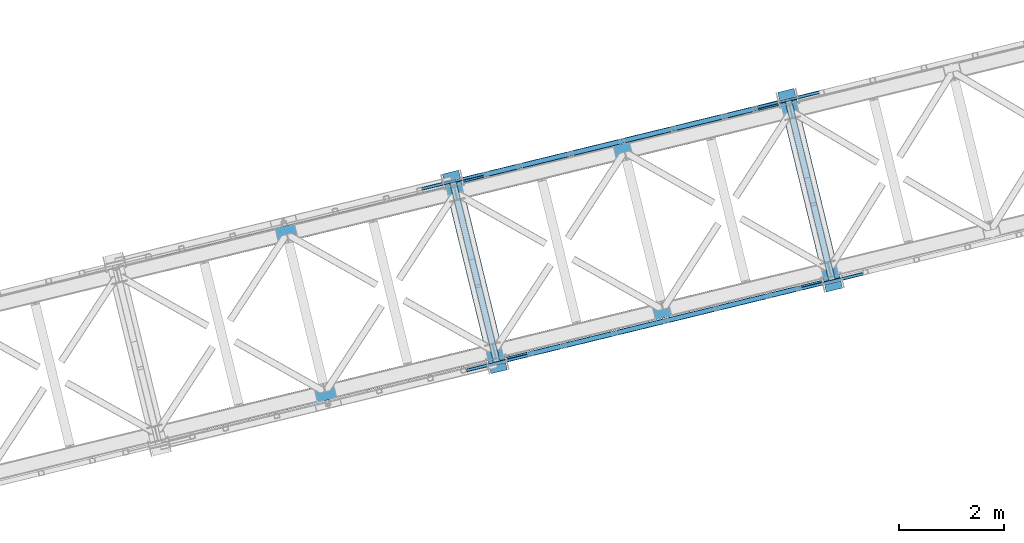
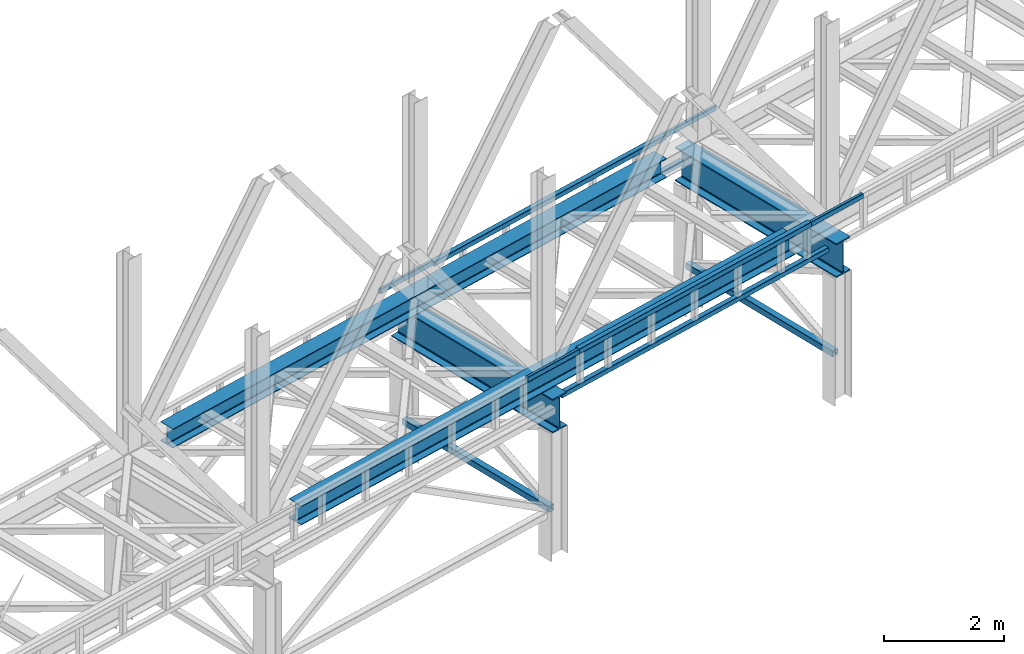
# One storey, part 17 of 92: 12 beams, 2 members.
"""IFC4 building model written with IfcOpenShell, lengths in millimetres."""

from ifc_helpers import new_model, entity, si_unit, converted_unit, derived_unit, direction, frame, origin, place, context, subcontext, project, spatial, indexed_curve, outline, extrude, material, type_object, element, save


model = new_model("IFC4")

# Units and contexts
model_context = context("Model", 3, precision=0.01, world=origin(), true_north=direction((6.12303176911189e-17, 1.0)))
plan_context = context("Plan", 3, precision=0.01, world=origin(), true_north=direction((6.12303176911189e-17, 1.0)))
body_context = subcontext(model_context, "Body", "Model", "MODEL_VIEW")
ifc_project = project(units=[si_unit("LENGTHUNIT", "METRE", prefix="MILLI"), si_unit("AREAUNIT", "SQUARE_METRE"), si_unit("VOLUMEUNIT", "CUBIC_METRE"), converted_unit("PLANEANGLEUNIT", "DEGREE", entity("IfcRatioMeasure", 0.0174532925199433), si_unit("PLANEANGLEUNIT", "RADIAN"), dimensions=[0, 0, 0, 0, 0, 0, 0]), si_unit("MASSUNIT", "GRAM", prefix="KILO"), derived_unit("MASSDENSITYUNIT", [(si_unit("MASSUNIT", "GRAM", prefix="KILO"), 1), (si_unit("LENGTHUNIT", "METRE"), -3)]), derived_unit("MOMENTOFINERTIAUNIT", [(si_unit("LENGTHUNIT", "METRE"), 4)]), si_unit("TIMEUNIT", "SECOND"), si_unit("FREQUENCYUNIT", "HERTZ"), si_unit("THERMODYNAMICTEMPERATUREUNIT", "DEGREE_CELSIUS"), derived_unit("THERMALTRANSMITTANCEUNIT", [(si_unit("MASSUNIT", "GRAM", prefix="KILO"), 1), (si_unit("THERMODYNAMICTEMPERATUREUNIT", "KELVIN"), -1), (si_unit("TIMEUNIT", "SECOND"), -3)]), derived_unit("VOLUMETRICFLOWRATEUNIT", [(si_unit("LENGTHUNIT", "METRE"), 3), (si_unit("TIMEUNIT", "SECOND"), -1)]), derived_unit("MASSFLOWRATEUNIT", [(si_unit("MASSUNIT", "GRAM", prefix="KILO"), 1), (si_unit("TIMEUNIT", "SECOND"), -1)]), derived_unit("ROTATIONALFREQUENCYUNIT", [(si_unit("TIMEUNIT", "SECOND"), -1)]), si_unit("ELECTRICCURRENTUNIT", "AMPERE"), si_unit("ELECTRICVOLTAGEUNIT", "VOLT"), si_unit("POWERUNIT", "WATT"), si_unit("FORCEUNIT", "NEWTON", prefix="KILO"), si_unit("ILLUMINANCEUNIT", "LUX"), si_unit("LUMINOUSFLUXUNIT", "LUMEN"), si_unit("LUMINOUSINTENSITYUNIT", "CANDELA"), derived_unit("USERDEFINED", [(si_unit("MASSUNIT", "GRAM", prefix="KILO"), -1), (si_unit("LENGTHUNIT", "METRE"), -2), (si_unit("TIMEUNIT", "SECOND"), 3), (si_unit("LUMINOUSFLUXUNIT", "LUMEN"), 1)]), derived_unit("LINEARVELOCITYUNIT", [(si_unit("LENGTHUNIT", "METRE"), 1), (si_unit("TIMEUNIT", "SECOND"), -1)]), si_unit("PRESSUREUNIT", "PASCAL"), derived_unit("USERDEFINED", [(si_unit("LENGTHUNIT", "METRE"), -2), (si_unit("MASSUNIT", "GRAM", prefix="KILO"), 1), (si_unit("TIMEUNIT", "SECOND"), -2)]), derived_unit("LINEARFORCEUNIT", [(si_unit("MASSUNIT", "GRAM", prefix="KILO"), 1), (si_unit("LENGTHUNIT", "METRE"), 1), (si_unit("TIMEUNIT", "SECOND"), -2), (si_unit("LENGTHUNIT", "METRE"), -1)]), derived_unit("PLANARFORCEUNIT", [(si_unit("MASSUNIT", "GRAM", prefix="KILO"), 1), (si_unit("LENGTHUNIT", "METRE"), 1), (si_unit("TIMEUNIT", "SECOND"), -2), (si_unit("LENGTHUNIT", "METRE"), -2)])], contexts=[model_context, plan_context])

# Site, building, storey
site_placement = place(None, origin())
site = spatial("IfcSite", under=ifc_project, at=site_placement, CompositionType="ELEMENT")
building_placement = place(site_placement, origin())
building = spatial("IfcBuilding", under=site, at=building_placement, CompositionType="ELEMENT")
storey_placement = place(building_placement, frame((0.0, 0.0, 15900.0)))
storey = spatial("IfcBuildingStorey", under=building, at=storey_placement, Name="05", CompositionType="ELEMENT", Elevation=15900.0)

# Beams
ifc_material = material(Name="Metal painted (White)")
beam_type = type_object("IfcBeamType", PredefinedType="BEAM")
placement = place(storey_placement, origin())
element("IfcBeam", 1, at=placement, inside=storey, type_object=beam_type, material=ifc_material, ObjectType="Steel Beam", PredefinedType="BEAM", context=body_context, shape_type="SweptSolid", body=[
    extrude(outline(indexed_curve([(-345.500000000002, -159.999999999997), (-322.5, -159.999999999997), (-322.5, -37.4999999999995), (-320.216385975338, -26.019497029052), (-313.713203435595, -16.2867965644011), (-303.980502970953, -9.78361402465815), (-292.499999999998, -7.49999999999633), (292.500000000001, -7.49999999999633), (303.980502970953, -9.78361402465815), (313.713203435597, -16.2867965644011), (320.21638597534, -26.019497029052), (322.5, -37.4999999999995), (322.5, -159.999999999997), (345.499999999997, -159.999999999997), (345.499999999997, 159.999999999997), (322.5, 159.999999999997), (322.5, 37.4999999999995), (320.21638597534, 26.019497029052), (313.713203435597, 16.2867965644011), (303.980502970953, 9.78361402465815), (292.500000000001, 7.50000000000079), (-292.499999999998, 7.50000000000526), (-303.98050297095, 9.78361402466262), (-313.713203435591, 16.2867965644011), (-320.216385975338, 26.0194970290475), (-322.5, 37.4999999999995), (-322.5, 160.000000000002), (-345.500000000002, 159.999999999997), (-345.500000000002, -159.999999999997)], self_intersect=False)), frame((-35697.8, 8488.15, 2947.5), z_axis=(-0.236826092990338, 0.971552058141473, 0.0), x_axis=(0.0, 0.0, 1.0)), (0.0, 0.0, 1.0), 3899.99999999999),
])
element("IfcBeam", 2, at=placement, inside=storey, type_object=beam_type, material=ifc_material, ObjectType="Steel Beam", PredefinedType="BEAM", context=body_context, shape_type="SweptSolid", body=[
    extrude(outline(indexed_curve([(-345.500000000002, -159.999999999992), (-322.5, -159.999999999992), (-322.5, -37.4999999999948), (-320.216385975338, -26.0194970290473), (-313.713203435595, -16.2867965643967), (-303.980502970953, -9.78361402465343), (-292.499999999998, -7.49999999999633), (292.500000000001, -7.49999999999633), (303.980502970953, -9.78361402465343), (313.713203435597, -16.2867965643967), (320.21638597534, -26.0194970290473), (322.5, -37.4999999999948), (322.5, -159.999999999992), (345.499999999997, -159.999999999992), (345.499999999997, 160.000000000006), (322.5, 160.000000000006), (322.5, 37.5000000000037), (320.21638597534, 26.0194970290562), (313.713203435597, 16.2867965644056), (303.980502970953, 9.78361402466287), (292.500000000001, 7.50000000000526), (-292.499999999998, 7.50000000000526), (-303.98050297095, 9.78361402466708), (-313.713203435591, 16.2867965644014), (-320.216385975338, 26.019497029052), (-322.5, 37.5000000000037), (-322.5, 160.000000000001), (-345.500000000002, 160.000000000006), (-345.500000000002, -159.999999999992)], self_intersect=False)), frame((-29334.14, 10039.36, 2947.5), z_axis=(-0.23682609299033, 0.971552058141475, 0.0), x_axis=(0.0, 0.0, 1.0)), (0.0, 0.0, 1.0), 3899.99999999999),
])
element("IfcBeam", 3, at=placement, inside=storey, type_object=beam_type, material=ifc_material, ObjectType="Steel Beam", PredefinedType="BEAM", context=body_context, shape_type="SweptSolid", body=[
    extrude(outline(indexed_curve([(-195.999999999999, -150.000000000003), (-179.999999999996, -150.000000000003), (-179.999999999996, -27.7500000000041), (-178.325349715245, -19.3309644879692), (-173.556349186101, -12.1936508138986), (-166.419035512029, -7.42465028475491), (-157.999999999997, -5.7500000000032), (158.000000000005, -5.7500000000032), (166.419035512033, -7.42465028475491), (173.556349186107, -12.1936508138986), (178.325349715251, -19.3309644879692), (180.0, -27.7500000000041), (180.0, -150.000000000003), (196.000000000005, -150.000000000003), (196.000000000005, 149.999999999998), (180.0, 149.999999999998), (180.0, 27.7499999999978), (178.325349715251, 19.330964487965), (173.556349186107, 12.1936508138923), (166.419035512033, 7.42465028474965), (158.000000000005, 5.74999999999584), (-157.999999999997, 5.74999999999584), (-166.419035512029, 7.42465028474965), (-173.556349186101, 12.1936508138933), (-178.325349715245, 19.330964487965), (-179.999999999996, 27.7499999999978), (-179.999999999996, 150.0), (-195.999999999999, 149.999999999998), (-195.999999999999, -150.000000000003)], self_intersect=False)), frame((-41354.67, 7520.94, 3489.0), z_axis=(0.971552058141476, 0.236826092990324, 0.0), x_axis=(0.0, 0.0, 1.0)), (0.0, 0.0, 1.0), 11400.0),
])
element("IfcBeam", 4, at=placement, inside=storey, type_object=beam_type, material=ifc_material, ObjectType="Steel Beam", PredefinedType="BEAM", context=body_context, shape_type="SweptSolid", body=[
    extrude(outline(indexed_curve([(-195.999999999999, -150.000000000002), (-179.999999999996, -150.000000000002), (-179.999999999996, -27.750000000002), (-178.325349715245, -19.3309644879681), (-173.556349186101, -12.1936508138975), (-166.419035512029, -7.42465028475491), (-157.999999999997, -5.75000000000215), (158.000000000005, -5.75000000000215), (166.419035512033, -7.42465028475491), (173.556349186107, -12.1936508138975), (178.325349715251, -19.3309644879681), (180.0, -27.750000000002), (180.0, -150.000000000002), (196.000000000005, -150.000000000002), (196.000000000005, 149.999999999998), (180.0, 149.999999999998), (180.0, 27.7499999999978), (178.325349715251, 19.330964487966), (173.556349186107, 12.1936508138933), (166.419035512033, 7.4246502847507), (158.000000000005, 5.74999999999794), (-157.999999999997, 5.74999999999794), (-166.419035512029, 7.4246502847486), (-173.556349186101, 12.1936508138912), (-178.325349715247, 19.330964487966), (-179.999999999996, 27.7499999999957), (-179.999999999996, 149.999999999998), (-195.999999999999, 149.999999999998), (-195.999999999999, -150.000000000002)], self_intersect=False)), frame((-42088.83, 10532.75, 3489.0), z_axis=(0.971552058141477, 0.236826092990322, 0.0), x_axis=(0.0, 0.0, 1.0)), (0.0, 0.0, 1.0), 11400.0),
])
element("IfcBeam", 5, at=placement, inside=storey, type_object=beam_type, material=ifc_material, ObjectType="Steel Beam", PredefinedType="BEAM", context=body_context, shape_type="SweptSolid", body=[
    extrude(outline(indexed_curve([(29.4768951152948, -56.8428769008151), (33.3787015556177, -56.8428769008151), (36.9835006656516, -55.3497202198128), (39.7424944584837, -52.5907264269822), (41.2356511394923, -48.9859273169492), (56.8428769008144, 29.4768951153021), (56.8428769008163, 33.3787015556236), (55.3497202198083, 36.983500665662), (52.5907264269817, 39.7424944584911), (48.9859273169474, 41.2356511394989), (-29.4768951153043, 56.8428769008214), (-33.3787015556268, 56.8428769008235), (-36.9835006656611, 55.3497202198191), (-39.7424944584921, 52.5907264269883), (-41.2356511395007, 48.9859273169553), (-56.8428769008228, -29.476895115296), (-56.8428769008247, -33.3787015556175), (-55.3497202198188, -36.9835006656555), (-52.5907264269907, -39.7424944584827), (-48.9859273169579, -41.2356511394924), (29.4768951152948, -56.8428769008151)], self_intersect=False), holes=[indexed_curve([(-50.9634988887243, -25.5484203233641), (-37.307176347567, 43.1065493048579), (-35.8140196665605, 46.7113484148914), (-33.0550258737274, 49.4703422077217), (-29.450226763691, 50.9634988887257), (-25.5484203233706, 50.963498888724), (43.106549304852, 37.3071763475664), (46.7113484148832, 35.8140196665592), (49.4703422077129, 33.0550258737295), (50.9634988887188, 29.4502267636915), (50.9634988887169, 25.54842032337), (37.3071763475586, -43.1065493048518), (35.81401966655, -46.7113484148849), (33.0550258737224, -49.4703422077141), (29.4502267636851, -50.9634988887179), (25.5484203233636, -50.963498888716), (-43.1065493048565, -37.3071763475567), (-46.7113484148907, -35.8140196665489), (-49.4703422077195, -33.0550258737194), (-50.9634988887242, -29.450226763686), (-50.9634988887243, -25.5484203233641)], self_intersect=False)]), frame((-36379.75, 12130.26, 3118.0), z_axis=(0.971552058141621, 0.236826092989728, 0.0), x_axis=(-0.232275546019818, 0.952883957770662, 0.195090322016531)), (0.0, 0.0, 1.0), 6149.99999999998),
])
element("IfcBeam", 6, at=placement, inside=storey, type_object=beam_type, material=ifc_material, ObjectType="Steel Beam", PredefinedType="BEAM", context=body_context, shape_type="SweptSolid", body=[
    extrude(outline(indexed_curve([(29.4768951153914, -56.8428769007589), (33.378701555713, -56.8428769007589), (36.9835006657449, -55.3497202197486), (39.742494458576, -52.590726426912), (41.2356511395787, -48.9859273168765), (56.8428769007726, 29.4768951154003), (56.8428769007651, 33.3787015557224), (55.3497202197521, 36.9835006657516), (52.5907264269217, 39.7424944585804), (48.985927316883, 41.2356511395828), (-29.4768951153921, 56.8428769007767), (-33.3787015557146, 56.8428769007724), (-36.9835006657473, 55.3497202197579), (-39.7424944585747, 52.5907264269294), (-41.2356511395774, 48.9859273168939), (-56.8428769007734, -29.4768951153824), (-56.8428769007669, -33.3787015557044), (-55.3497202197555, -36.9835006657421), (-52.5907264269213, -39.7424944585673), (-48.9859273168837, -41.235651139565), (29.4768951153914, -56.8428769007589)], self_intersect=False), holes=[indexed_curve([(-50.9634988886772, -25.5484203234418), (-37.307176347632, 43.1065493048025), (-35.8140196666283, 46.7113484148378), (-33.055025873804, 49.4703422076669), (-29.4502267637722, 50.9634988886772), (-25.5484203234488, 50.9634988886857), (43.106549304796, 37.3071763476402), (46.7113484148319, 35.8140196666341), (49.470342207663, 33.0550258738095), (50.9634988886741, 29.4502267637807), (50.9634988886805, 25.5484203234587), (37.3071763476354, -43.1065493047855), (35.8140196666347, -46.7113484148214), (33.0550258738057, -49.4703422076584), (29.4502267637739, -50.9634988886687), (25.5484203234514, -50.963498888673), (-43.1065493047935, -37.3071763476275), (-46.7113484148281, -35.814019666626), (-49.4703422076613, -33.055025873801), (-50.9634988886727, -29.4502267637633), (-50.9634988886772, -25.5484203234418)], self_intersect=False)]), frame((-35991.13, 12224.99, 3830.0), z_axis=(0.971552058141621, 0.236826092989728, 0.0), x_axis=(0.232275546019893, -0.952883957770972, -0.19509032201493)), (0.0, 0.0, 1.0), 5349.99999999999),
])
element("IfcBeam", 7, at=placement, inside=storey, type_object=beam_type, material=ifc_material, ObjectType="Steel Beam", PredefinedType="BEAM", context=body_context, shape_type="SweptSolid", body=[
    extrude(outline(indexed_curve([(9.86118950714821, -52.94107046051), (13.7629959474724, -52.94107046051), (17.3677950575093, -51.4479137795159), (20.1267888503473, -48.6889199866879), (21.6199455313576, -45.0841208766564), (37.2271712928086, 33.3787015555692), (37.2271712928189, 37.2805079958903), (35.7340146118184, 40.8853071059286), (32.9750208189941, 43.6443008987626), (29.3702217089642, 45.1374575797804), (-9.86118950715112, 52.9410704605061), (-13.7629959474724, 52.94107046051), (-17.3677950575122, 51.447913779512), (-20.1267888503473, 48.6889199866879), (-21.6199455313597, 45.0841208766568), (-37.2271712928107, -33.3787015555687), (-37.2271712928189, -37.2805079958903), (-35.7340146118213, -40.8853071059325), (-32.9750208189941, -43.6443008987626), (-29.370221708965, -45.1374575797846), (9.86118950714821, -52.94107046051)], self_intersect=False), holes=[indexed_curve([(-31.3477932807058, -29.4502267636464), (-17.6914707394355, 39.204742864553), (-16.1983140584179, 42.8095419745831), (-13.439320265588, 45.5685357674083), (-9.83452115555026, 47.0616924484066), (-5.9327147152257, 47.0616924483977), (23.4908436968584, 41.2089827878538), (27.0956428068893, 39.7158261068403), (29.8546365997166, 36.9568323140057), (31.3477932807141, 33.3520332039679), (31.3477932807058, 29.4502267636464), (17.6914707394355, -39.204742864553), (16.1983140584221, -42.8095419745839), (13.4393202655851, -45.5685357674121), (9.83452115554819, -47.0616924484062), (5.93271471522983, -47.0616924483985), (-23.4908436968584, -41.2089827878538), (-27.0956428068893, -39.7158261068403), (-29.8546365997094, -36.9568323140071), (-31.3477932807141, -33.3520332039679), (-31.3477932807058, -29.4502267636464)], self_intersect=False)]), frame((-37161.73, 11960.23, 3830.0), z_axis=(0.971552058141752, 0.236826092989194, 0.0), x_axis=(-0.232275546019742, 0.952883957770353, 0.195090322018133)), (0.0, 0.0, 1.0), 1199.99999999998),
])
element("IfcBeam", 8, at=placement, inside=storey, type_object=beam_type, material=ifc_material, ObjectType="Steel Beam", PredefinedType="BEAM", context=body_context, shape_type="SweptSolid", body=[
    extrude(outline(indexed_curve([(9.86118950714344, -52.9410704605112), (13.7629959474656, -52.9410704605112), (17.3677950575047, -51.4479137795179), (20.1267888503399, -48.6889199866896), (21.6199455313537, -45.0841208766589), (37.2271712928143, 33.3787015555648), (37.227171292823, 37.2805079958863), (35.7340146118239, 40.8853071059246), (32.9750208189968, 43.6443008987596), (29.3702217089691, 45.1374575797773), (-9.86118950714429, 52.9410704605069), (-13.7629959474676, 52.9410704605116), (-17.3677950575055, 51.4479137795136), (-20.1267888503399, 48.6889199866896), (-21.6199455313537, 45.0841208766589), (-37.2271712928143, -33.3787015555648), (-37.2271712928209, -37.2805079958867), (-35.7340146118227, -40.8853071059293), (-32.9750208189989, -43.6443008987591), (-29.3702217089699, -45.1374575797815), (9.86118950714344, -52.9410704605112)], self_intersect=False), holes=[indexed_curve([(-31.3477932807069, -29.4502267636435), (-17.6914707394291, 39.2047428645544), (-16.1983140584143, 42.8095419745849), (-13.439320265582, 45.5685357674094), (-9.83452115554203, 47.061692448407), (-5.9327147152216, 47.0616924483985), (23.4908436968629, 41.2089827878513), (27.0956428068946, 39.7158261068372), (29.8546365997175, 36.9568323140031), (31.3477932807197, 33.3520332039642), (31.3477932807111, 29.4502267636427), (17.6914707394333, -39.2047428645553), (16.1983140584184, -42.8095419745858), (13.4393202655811, -45.5685357674137), (9.83452115554409, -47.0616924484074), (5.93271471522366, -47.0616924483989), (-23.4908436968609, -41.2089827878517), (-27.0956428068895, -39.7158261068383), (-29.8546365997142, -36.9568323140082), (-31.3477932807156, -33.352033203965), (-31.3477932807069, -29.4502267636435)], self_intersect=False)]), frame((-30796.99, 13507.06, 3830.0), z_axis=(0.971552058141691, 0.236826092989445, 0.0), x_axis=(-0.232275546019865, 0.952883957770302, 0.195090322018236)), (0.0, 0.0, 1.0), 1200.00000000001),
])
element("IfcBeam", 9, at=placement, inside=storey, type_object=beam_type, material=ifc_material, ObjectType="Steel Beam", PredefinedType="BEAM", context=body_context, shape_type="SweptSolid", body=[
    extrude(outline(indexed_curve([(29.4768951153284, -56.8428769008039), (33.3787015556499, -56.8428769008039), (36.9835006656849, -55.3497202197958), (39.7424944585137, -52.5907264269679), (41.2356511395206, -48.9859273169341), (56.8428769008042, 29.4768951153248), (56.8428769008037, 33.3787015556486), (55.349720219797, 36.9835006656857), (52.5907264269665, 39.7424944585117), (48.9859273169325, 41.2356511395176), (-29.4768951153288, 56.8428769008018), (-33.3787015556503, 56.8428769008018), (-36.9835006656844, 55.3497202197979), (-39.7424944585142, 52.5907264269658), (-41.2356511395214, 48.9859273169299), (-56.8428769008051, -29.476895115329), (-56.8428769008041, -33.3787015556507), (-55.3497202197966, -36.9835006656836), (-52.5907264269669, -39.7424944585138), (-48.985927316933, -41.2356511395197), (29.4768951153284, -56.8428769008039)], self_intersect=False), holes=[indexed_curve([(-50.9634988887085, -25.5484203233942), (-37.3071763475859, 43.1065493048346), (-35.8140196665801, 46.7113484148686), (-33.0550258737493, 49.4703422077006), (-29.4502267637143, 50.9634988887087), (-25.5484203233908, 50.9634988887083), (43.1065493048363, 37.3071763475849), (46.7113484148724, 35.8140196665786), (49.470342207701, 33.0550258737486), (50.9634988887077, 29.4502267637115), (50.9634988887076, 25.54842032339), (37.307176347583, -43.1065493048385), (35.8140196665761, -46.7113484148723), (33.0550258737489, -49.4703422077027), (29.4502267637147, -50.9634988887066), (25.5484203233923, -50.9634988887064), (-43.1065493048349, -37.307176347583), (-46.7113484148709, -35.8140196665767), (-49.4703422076989, -33.055025873749), (-50.9634988887075, -29.4502267637159), (-50.9634988887085, -25.5484203233942)], self_intersect=False)]), frame((-35548.72, 8721.08, 3118.0), z_axis=(0.971552058141591, 0.236826092989854, 0.0), x_axis=(-0.232275546019904, 0.95288395777074, 0.195090322016049)), (0.0, 0.0, 1.0), 6149.99999999998),
])
element("IfcBeam", 10, at=placement, inside=storey, type_object=beam_type, material=ifc_material, ObjectType="Steel Beam", PredefinedType="BEAM", context=body_context, shape_type="SweptSolid", body=[
    extrude(outline(indexed_curve([(29.4768951153914, -56.842876900761), (33.378701555712, -56.842876900761), (36.983500665745, -55.3497202197511), (39.7424944585721, -52.5907264269138), (41.235651139575, -48.9859273168784), (56.8428769007732, 29.4768951153975), (56.842876900768, 33.3787015557192), (55.3497202197561, 36.9835006657483), (52.5907264269239, 39.7424944585777), (48.9859273168883, 41.2356511395796), (-29.476895115389, 56.8428769007782), (-33.3787015557115, 56.8428769007741), (-36.9835006657453, 55.34972021976), (-39.7424944585708, 52.5907264269312), (-41.2356511395737, 48.9859273168958), (-56.8428769007719, -29.4768951153801), (-56.8428769007667, -33.3787015557018), (-55.3497202197565, -36.9835006657394), (-52.5907264269234, -39.7424944585645), (-48.9859273168859, -41.2356511395624), (29.4768951153914, -56.842876900761)], self_intersect=False), holes=[indexed_curve([(-50.9634988886785, -25.5484203234391), (-37.3071763476287, 43.1065493048042), (-35.8140196666226, 46.711348414839), (-33.0550258738003, 49.4703422076684), (-29.4502267637694, 50.9634988886787), (-25.548420323445, 50.9634988886868), (43.106549304797, 37.3071763476382), (46.7113484148338, 35.8140196666316), (49.4703422076658, 33.0550258738067), (50.9634988886777, 29.4502267637776), (50.9634988886819, 25.5484203234561), (37.3071763476341, -43.1065493047876), (35.8140196666342, -46.7113484148237), (33.055025873803, -49.4703422076601), (29.4502267637711, -50.9634988886702), (25.5484203234486, -50.9634988886743), (-43.1065493047934, -37.3071763476257), (-46.711348414829, -35.8140196666237), (-49.4703422076652, -33.055025873798), (-50.9634988886733, -29.4502267637608), (-50.9634988886785, -25.5484203234391)], self_intersect=False)]), frame((-35160.1, 8815.81, 3830.0), z_axis=(0.971552058141591, 0.236826092989854, 0.0), x_axis=(0.232275546019955, -0.952883957770947, -0.195090322014981)), (0.0, 0.0, 1.0), 5349.99999999999),
])
element("IfcBeam", 11, at=placement, inside=storey, type_object=beam_type, material=ifc_material, ObjectType="Steel Beam", PredefinedType="BEAM", context=body_context, shape_type="SweptSolid", body=[
    extrude(outline(indexed_curve([(9.86118950714636, -52.9410704605107), (13.7629959474695, -52.9410704605107), (17.3677950575075, -51.447913779517), (20.1267888503426, -48.6889199866885), (21.6199455313572, -45.0841208766579), (37.2271712928125, 33.3787015555668), (37.2271712928199, 37.2805079958885), (35.7340146118217, 40.8853071059265), (32.9750208189965, 43.6443008987609), (29.3702217089666, 45.1374575797788), (-9.8611895071472, 52.9410704605064), (-13.7629959474695, 52.9410704605107), (-17.3677950575084, 51.4479137795127), (-20.1267888503426, 48.6889199866885), (-21.6199455313572, 45.0841208766579), (-37.2271712928125, -33.3787015555668), (-37.2271712928199, -37.2805079958885), (-35.7340146118225, -40.8853071059308), (-32.9750208189965, -43.6443008987609), (-29.3702217089675, -45.1374575797831), (9.86118950714636, -52.9410704605107)], self_intersect=False), holes=[indexed_curve([(-31.3477932807053, -29.4502267636452), (-17.6914707394323, 39.2047428645537), (-16.1983140584177, 42.8095419745843), (-13.4393202655865, 45.5685357674091), (-9.83452115554665, 47.0616924484069), (-5.93271471522212, 47.0616924483978), (23.4908436968607, 41.2089827878526), (27.0956428068914, 39.7158261068389), (29.8546365997166, 36.9568323140045), (31.3477932807159, 33.3520332039663), (31.3477932807084, 29.4502267636446), (17.6914707394344, -39.2047428645542), (16.1983140584197, -42.8095419745847), (13.4393202655846, -45.5685357674132), (9.83452115554871, -47.0616924484073), (5.93271471522725, -47.0616924483988), (-23.4908436968597, -41.2089827878528), (-27.0956428068894, -39.7158261068393), (-29.8546365997112, -36.95683231401), (-31.3477932807138, -33.3520332039667), (-31.3477932807053, -29.4502267636452)], self_intersect=False)]), frame((-36321.23, 8512.19, 3830.0), z_axis=(0.971552058141721, 0.236826092989319, 0.0), x_axis=(-0.232275546019804, 0.952883957770327, 0.195090322018185)), (0.0, 0.0, 1.0), 1199.99999999998),
])
element("IfcBeam", 12, at=placement, inside=storey, type_object=beam_type, material=ifc_material, ObjectType="Steel Beam", PredefinedType="BEAM", context=body_context, shape_type="SweptSolid", body=[
    extrude(outline(indexed_curve([(9.86118950714821, -52.94107046051), (13.7629959474724, -52.94107046051), (17.3677950575093, -51.4479137795159), (20.1267888503473, -48.6889199866879), (21.6199455313597, -45.0841208766568), (37.2271712928107, 33.3787015555687), (37.2271712928189, 37.2805079958903), (35.7340146118184, 40.8853071059286), (32.9750208189941, 43.6443008987626), (29.3702217089642, 45.1374575797804), (-9.86118950714905, 52.9410704605057), (-13.7629959474724, 52.94107046051), (-17.3677950575101, 51.4479137795116), (-20.1267888503473, 48.6889199866879), (-21.6199455313597, 45.0841208766568), (-37.2271712928107, -33.3787015555687), (-37.2271712928189, -37.2805079958903), (-35.7340146118193, -40.8853071059329), (-32.9750208189941, -43.6443008987626), (-29.370221708965, -45.1374575797846), (9.86118950714821, -52.94107046051)], self_intersect=False), holes=[indexed_curve([(-31.3477932807017, -29.4502267636472), (-17.6914707394334, 39.2047428645526), (-16.1983140584179, 42.8095419745831), (-13.439320265588, 45.5685357674083), (-9.83452115555026, 47.0616924484066), (-5.93271471522776, 47.0616924483981), (23.4908436968584, 41.2089827878538), (27.0956428068893, 39.7158261068403), (29.8546365997135, 36.9568323140063), (31.3477932807161, 33.3520332039675), (31.3477932807079, 29.450226763646), (17.6914707394396, -39.2047428645539), (16.1983140584221, -42.8095419745839), (13.4393202655851, -45.5685357674121), (9.83452115555026, -47.0616924484066), (5.93271471522776, -47.0616924483981), (-23.4908436968584, -41.2089827878538), (-27.0956428068872, -39.7158261068407), (-29.8546365997103, -36.9568323140114), (-31.3477932807099, -33.3520332039688), (-31.3477932807017, -29.4502267636472)], self_intersect=False)]), frame((-29957.56, 10063.4, 3830.0), z_axis=(0.971552058141752, 0.236826092989194, 0.0), x_axis=(-0.232275546019742, 0.952883957770353, 0.195090322018133)), (0.0, 0.0, 1.0), 1200.00000000001),
])

# Members
member_type_1 = type_object("IfcMemberType", PredefinedType="BRACE")
element("IfcMember", 13, at=placement, inside=storey, type_object=member_type_1, ObjectType="Steel Vertical Brace", PredefinedType="BRACE", context=body_context, shape_type="SweptSolid", body=[
    extrude(outline(indexed_curve([(41.2596526560083, -71.9315025750552), (44.3810978082601, -71.9315025750552), (47.2649370962886, -70.7369772302474), (49.4721321305551, -68.5297821959818), (50.6666574753592, -65.6459429079524), (71.9315025750527, 41.2596526560115), (71.931502575051, 44.3810978082705), (70.736977230239, 47.2649370962958), (68.5297821959735, 49.4721321305612), (65.6459429079506, 50.666657475363), (-41.2596526560082, 71.9315025750574), (-44.3810978082732, 71.9315025750578), (-47.2649370962978, 70.7369772302471), (-49.4721321305635, 68.5297821959857), (-50.6666574753676, 65.6459429079563), (-71.9315025750654, -41.2596526560068), (-71.931502575059, -44.3810978082667), (-70.7369772302526, -47.2649370962953), (-68.5297821959911, -49.4721321305577), (-65.6459429079545, -50.66665747536), (41.2596526560083, -71.9315025750552)], self_intersect=False), holes=[indexed_curve([(-67.2280001653862, -38.1168728224595), (-47.523877641812, 60.9424404982808), (-46.3293522970123, 63.826279786311), (-44.1221572627466, 66.0334748205724), (-41.2383179747225, 67.228000165381), (-38.1168728224609, 67.2280001653834), (60.942440498271, 47.5238776418136), (63.8262797863027, 46.32935229701), (66.0334748205641, 44.1221572627454), (67.2280001653714, 41.2383179747211), (67.2280001653731, 38.1168728224621), (47.5238776418037, -60.9424404982769), (46.329352297, -63.8262797863042), (44.1221572627374, -66.0334748205728), (41.2383179747098, -67.2280001653762), (38.1168728224528, -67.2280001653796), (-60.9424404982837, -47.5238776418089), (-63.8262797863146, -46.3293522970011), (-66.0334748205817, -44.1221572627441), (-67.2280001653882, -41.2383179747156), (-67.2280001653862, -38.1168728224595)], self_intersect=False)]), frame((-35744.8, 8680.95, 898.0), z_axis=(-0.236826092990371, 0.971552058141465, 0.0), x_axis=(-0.952883957770726, -0.232275546020376, 0.195090322015555)), (0.0, 0.0, 1.0), 3545.80325659093),
])
member_type_2 = type_object("IfcMemberType", PredefinedType="BRACE")
element("IfcMember", 14, at=placement, inside=storey, type_object=member_type_2, ObjectType="Steel Vertical Brace", PredefinedType="BRACE", context=body_context, shape_type="SweptSolid", body=[
    extrude(outline(indexed_curve([(41.2596526560248, -71.9315025750429), (44.3810978082809, -71.931502575043), (47.2649370963047, -70.7369772302335), (49.4721321305662, -68.5297821959665), (50.6666574753739, -65.6459429079376), (71.931502575041, 41.2596526560316), (71.9315025750339, 44.3810978082915), (70.7369772302253, 47.2649370963156), (68.5297821959636, 49.4721321305796), (65.6459429079359, 50.6666574753814), (-41.2596526560373, 71.9315025750476), (-44.3810978082938, 71.9315025750455), (-47.264937096318, 70.736977230234), (-49.4721321305833, 68.5297821959721), (-50.6666574753864, 65.6459429079423), (-71.9315025750493, -41.2596526560278), (-71.9315025750464, -44.3810978082868), (-70.736977230235, -47.2649370963159), (-68.5297821959724, -49.4721321305778), (-65.6459429079443, -50.6666574753776), (41.2596526560248, -71.9315025750429)], self_intersect=False), holes=[indexed_curve([(-67.2280001653793, -38.1168728224753), (-47.5238776418337, 60.9424404982684), (-46.3293522970306, 63.8262797862982), (-44.1221572627654, 66.0334748205624), (-41.238317974742, 67.2280001653697), (-38.116872822485, 67.2280001653739), (60.9424404982572, 47.5238776418307), (63.8262797862928, 46.3293522970228), (66.0334748205563, 44.1221572627651), (67.228000165364, 41.238317974739), (67.2280001653664, 38.1168728224801), (47.5238776418258, -60.9424404982647), (46.329352297014, -63.8262797862927), (44.1221572627529, -66.0334748205577), (41.2383179747296, -67.228000165365), (38.1168728224679, -67.2280001653683), (-60.9424404982702, -47.5238776418259), (-63.8262797863015, -46.3293522970211), (-66.0334748205608, -44.1221572627665), (-67.2280001653764, -41.2383179747344), (-67.2280001653793, -38.1168728224753)], self_intersect=False)]), frame((-29381.13, 10232.16, 898.0), z_axis=(-0.236826092990387, 0.971552058141461, 0.0), x_axis=(-0.952883957770777, -0.232275546020397, 0.195090322015281)), (0.0, 0.0, 1.0), 3545.80325659093),
])

save(model, "model.ifc")
